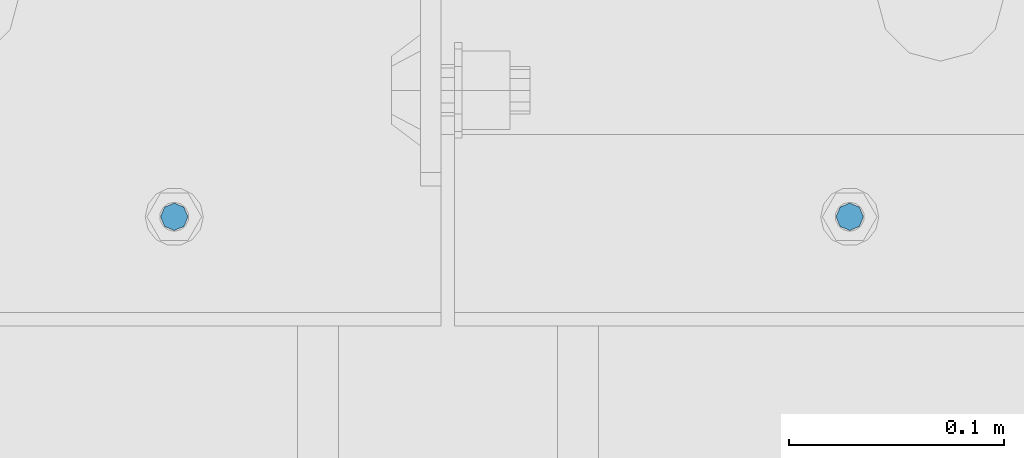
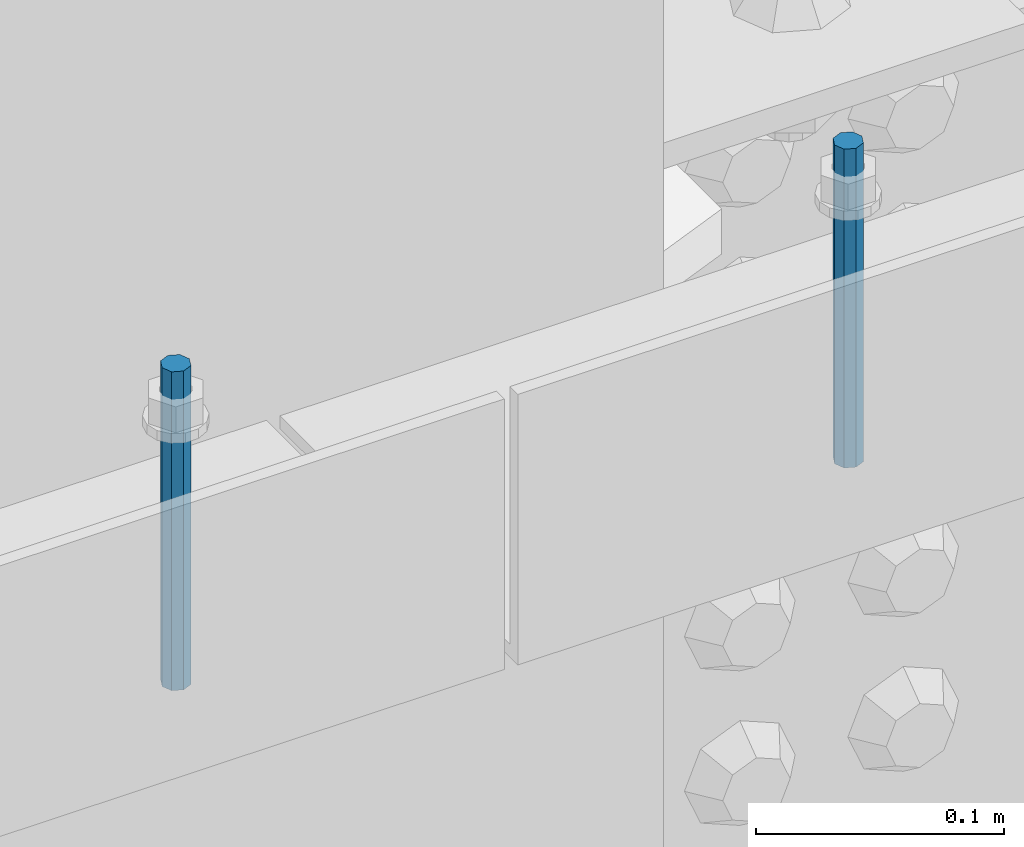
# One storey, part 455 of 1179: 2 columns, 2 elements without a shape of their own.
"""IFC2X3 building model written with IfcOpenShell, lengths in millimetres."""

from ifc_helpers import new_model, si_unit, frame, origin_with_axes, place, context, subcontext, project, spatial, faceted_brep, material, type_object, element, aggregate, save


model = new_model("IFC2X3")

# Units and contexts
model_context = context("Model", 3, precision=1e-05, world=origin_with_axes())
body_context = subcontext(model_context, "Body", "Model", "MODEL_VIEW")
ifc_project = project(units=[si_unit("LENGTHUNIT", "METRE", prefix="MILLI"), si_unit("AREAUNIT", "SQUARE_METRE"), si_unit("VOLUMEUNIT", "CUBIC_METRE"), si_unit("MASSUNIT", "GRAM", prefix="KILO"), si_unit("TIMEUNIT", "SECOND"), si_unit("PLANEANGLEUNIT", "RADIAN"), si_unit("SOLIDANGLEUNIT", "STERADIAN"), si_unit("THERMODYNAMICTEMPERATUREUNIT", "DEGREE_CELSIUS"), si_unit("LUMINOUSINTENSITYUNIT", "LUMEN")], contexts=[model_context])

# Site, building, storey
site_placement = place(None, origin_with_axes())
site = spatial("IfcSite", under=ifc_project, at=site_placement, CompositionType="ELEMENT")
building_placement = place(site_placement, origin_with_axes())
building = spatial("IfcBuilding", under=site, at=building_placement, Name="Undefined", CompositionType="ELEMENT")
storey_placement = place(building_placement, origin_with_axes())
storey = spatial("IfcBuildingStorey", under=building, at=storey_placement, Name="Undefined", CompositionType="ELEMENT", Elevation=0.0)

# Assembly, column
assembly_1_placement = place(storey_placement, origin_with_axes())
assembly_1 = element("IfcElementAssembly", 1, at=assembly_1_placement, inside=storey, Name="BEAM", AssemblyPlace="NOTDEFINED", PredefinedType="RIGID_FRAME")
ifc_material = material(Name="STEEL/A307")
column_type = type_object("IfcColumnType", PredefinedType="NOTDEFINED")
column_1_placement = place(assembly_1_placement, frame((16645.7315, 26720.8, 8020.05), z_axis=(0.0, 1.0, 0.0), x_axis=(0.0, 0.0, 1.0)))
column_1 = element("IfcColumn", 2, at=column_1_placement, type_object=column_type, material=ifc_material, Name="THREADED ROD", context=body_context, shape_type="Brep", body=[
    faceted_brep([(0.0, -6.34999999999854, 0.0), (0.0, -4.49012806053361, -4.49012806053452), (157.162499999999, -4.49012806053361, -4.49012806053361), (157.162499999999, -6.34999999999854, 0.0), (0.0, 0.0, -6.34999999999991), (157.162499999999, 0.0, -6.34999999999854), (0.0, 4.49012806053361, -4.49012806053452), (157.162499999999, 4.49012806053361, -4.49012806053361), (0.0, 6.34999999999854, 0.0), (157.162499999999, 6.34999999999854, 0.0), (0.0, 4.49012806053361, 4.49012806053452), (157.162499999999, 4.49012806053361, 4.49012806053361), (0.0, 0.0, 6.34999999999991), (157.162499999999, 0.0, 6.34999999999854), (0.0, -4.49012806053361, 4.49012806053452), (157.162499999999, -4.49012806053361, 4.49012806053361)], [[[0, 1, 2, 3]], [[1, 4, 5, 2]], [[4, 6, 7, 5]], [[6, 8, 9, 7]], [[8, 10, 11, 9]], [[10, 12, 13, 11]], [[12, 14, 15, 13]], [[14, 0, 3, 15]], [[5, 7, 9, 11, 13, 15, 3, 2]], [[14, 12, 10, 8, 6, 4, 1, 0]]]),
])
aggregate(assembly_1, [column_1])

assembly_2_placement = place(storey_placement, origin_with_axes())
assembly_2 = element("IfcElementAssembly", 3, at=assembly_2_placement, inside=storey, Name="BEAM", AssemblyPlace="NOTDEFINED", PredefinedType="RIGID_FRAME")
column_2_placement = place(assembly_2_placement, frame((16332.2, 26720.8, 8020.05), z_axis=(0.0, 1.0, 0.0), x_axis=(0.0, 0.0, 1.0)))
column_2 = element("IfcColumn", 4, at=column_2_placement, type_object=column_type, material=ifc_material, Name="THREADED ROD", context=body_context, shape_type="Brep", body=[
    faceted_brep([(0.0, -6.34999999999854, 0.0), (0.0, -4.49012806053361, -4.49012806053452), (157.162499999999, -4.49012806053361, -4.49012806053361), (157.162499999999, -6.34999999999854, 0.0), (0.0, 0.0, -6.34999999999991), (157.162499999999, 0.0, -6.34999999999854), (0.0, 4.49012806053361, -4.49012806053452), (157.162499999999, 4.49012806053361, -4.49012806053361), (0.0, 6.34999999999854, 0.0), (157.162499999999, 6.34999999999854, 0.0), (0.0, 4.49012806053361, 4.49012806053452), (157.162499999999, 4.49012806053361, 4.49012806053361), (0.0, 0.0, 6.34999999999991), (157.162499999999, 0.0, 6.34999999999854), (0.0, -4.49012806053361, 4.49012806053452), (157.162499999999, -4.49012806053361, 4.49012806053361)], [[[0, 1, 2, 3]], [[1, 4, 5, 2]], [[4, 6, 7, 5]], [[6, 8, 9, 7]], [[8, 10, 11, 9]], [[10, 12, 13, 11]], [[12, 14, 15, 13]], [[14, 0, 3, 15]], [[5, 7, 9, 11, 13, 15, 3, 2]], [[14, 12, 10, 8, 6, 4, 1, 0]]]),
])
aggregate(assembly_2, [column_2])

save(model, "model.ifc")
